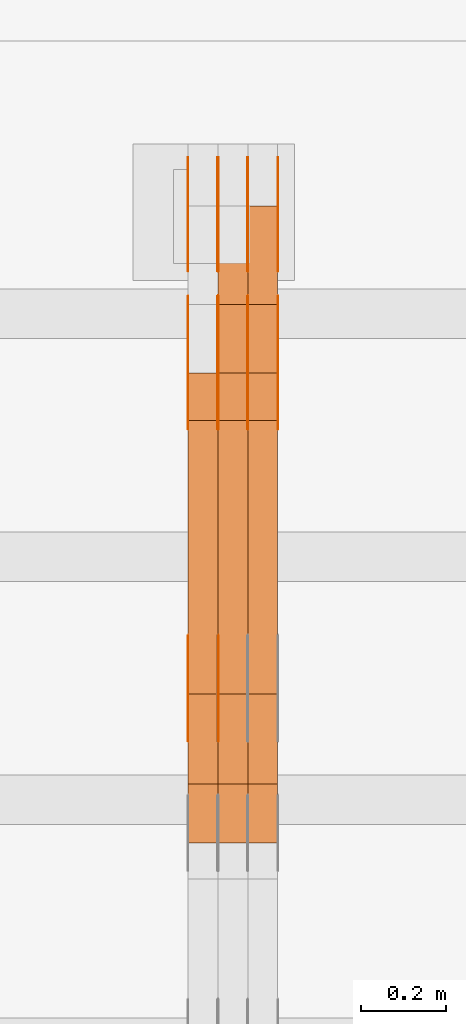
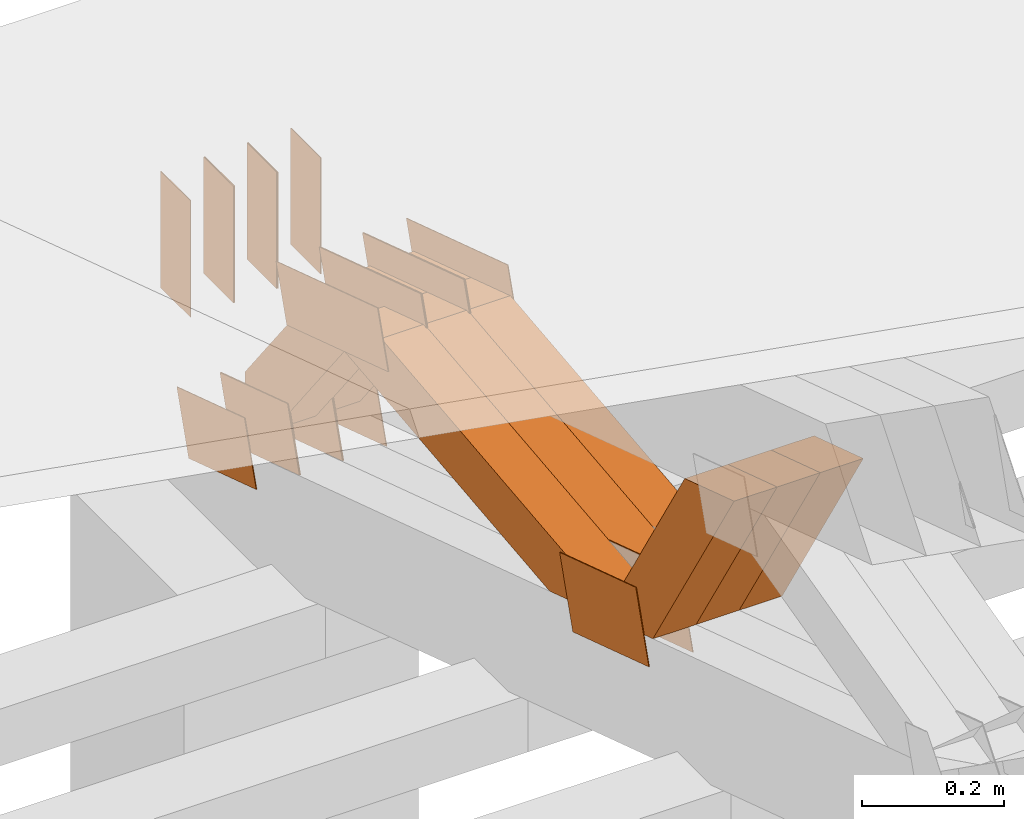
# One storey, part 360 of 385: 28 proxies.
"""IFC2X3 building model written with IfcOpenShell, lengths in millimetres."""

from ifc_helpers import new_model, entity, si_unit, converted_unit, derived_unit, direction, frame, frame_2d, origin, place, context, subcontext, project, spatial, polyline, rectangle, outline, extrude, source, transform, mapped, material, type_object, type_shapes, element, save


model = new_model("IFC2X3")

# Units and contexts
model_context = context("Model", 3, precision=0.01, world=origin(), true_north=direction((6.12303176911189e-17, 1.0)))
body_context = subcontext(model_context, "Body", "Model", "MODEL_VIEW")
ifc_project = project(units=[si_unit("LENGTHUNIT", "METRE", prefix="MILLI"), si_unit("AREAUNIT", "SQUARE_METRE"), si_unit("VOLUMEUNIT", "CUBIC_METRE"), converted_unit("PLANEANGLEUNIT", "DEGREE", entity("IfcRatioMeasure", 0.0174532925199433), si_unit("PLANEANGLEUNIT", "RADIAN"), dimensions=[0, 0, 0, 0, 0, 0, 0]), si_unit("MASSUNIT", "GRAM", prefix="KILO"), derived_unit("MASSDENSITYUNIT", [(si_unit("MASSUNIT", "GRAM", prefix="KILO"), 1), (si_unit("LENGTHUNIT", "METRE"), -3)]), si_unit("TIMEUNIT", "SECOND"), si_unit("FREQUENCYUNIT", "HERTZ"), si_unit("THERMODYNAMICTEMPERATUREUNIT", "DEGREE_CELSIUS"), derived_unit("THERMALTRANSMITTANCEUNIT", [(si_unit("MASSUNIT", "GRAM", prefix="KILO"), 1), (si_unit("THERMODYNAMICTEMPERATUREUNIT", "KELVIN"), -1), (si_unit("TIMEUNIT", "SECOND"), -3)]), derived_unit("VOLUMETRICFLOWRATEUNIT", [(si_unit("LENGTHUNIT", "METRE"), 3), (si_unit("TIMEUNIT", "SECOND"), -1)]), si_unit("ELECTRICCURRENTUNIT", "AMPERE"), si_unit("ELECTRICVOLTAGEUNIT", "VOLT"), si_unit("POWERUNIT", "WATT"), si_unit("FORCEUNIT", "NEWTON", prefix="KILO"), si_unit("ILLUMINANCEUNIT", "LUX"), si_unit("LUMINOUSFLUXUNIT", "LUMEN"), si_unit("LUMINOUSINTENSITYUNIT", "CANDELA"), derived_unit("USERDEFINED", [(si_unit("MASSUNIT", "GRAM", prefix="KILO"), -1), (si_unit("LENGTHUNIT", "METRE"), -2), (si_unit("TIMEUNIT", "SECOND"), 3), (si_unit("LUMINOUSFLUXUNIT", "LUMEN"), 1)]), derived_unit("LINEARVELOCITYUNIT", [(si_unit("LENGTHUNIT", "METRE"), 1), (si_unit("TIMEUNIT", "SECOND"), -1)]), si_unit("PRESSUREUNIT", "PASCAL"), derived_unit("USERDEFINED", [(si_unit("LENGTHUNIT", "METRE"), -2), (si_unit("MASSUNIT", "GRAM", prefix="KILO"), 1), (si_unit("TIMEUNIT", "SECOND"), -2)])], contexts=[model_context])

# Site, building, storey
site_placement = place(None, origin())
site = spatial("IfcSite", under=ifc_project, at=site_placement, CompositionType="ELEMENT")
building_placement = place(site_placement, origin())
building = spatial("IfcBuilding", under=site, at=building_placement, CompositionType="ELEMENT")
storey_placement = place(building_placement, origin())
storey = spatial("IfcBuildingStorey", under=building, at=storey_placement, Name="Default", CompositionType="ELEMENT", Elevation=0.0)

# Proxies
ifc_material_1 = material(Name="IfcSurfaceStyle #515950")
building_element_proxy_type_1 = type_object("IfcBuildingElementProxyType", PredefinedType="NOTDEFINED", material=ifc_material_1)
shared_shape_1 = source(origin(), body_context, "Body", "SweptSolid", [
    extrude(outline(polyline([(-100.000024997547, -54.0000105875654), (100.000088940899, -54.0000105875654), (99.9999100805868, 54.0000105875654), (-99.9999740239394, 54.0000105875654), (-100.000024997547, -54.0000105875654)])), frame((100.000088940899, 54.0000474633838, 0.0), z_axis=(0.0, 0.0, 1.0), x_axis=(-1.0, 0.0, 0.0)), (0.0, 0.0, 1.0), 1.3),
])
type_shapes(building_element_proxy_type_1, [shared_shape_1])
proxy_1_placement = place(building_placement, frame((42386.3, 26390.6212638563, 73.3227520411355), z_axis=(-1.0, 0.0, 0.0), x_axis=(0.0, -0.951056516295124, 0.309016994375039)))
element("IfcBuildingElementProxy", 1, at=proxy_1_placement, inside=storey, type_object=building_element_proxy_type_1, material=ifc_material_1, context=body_context, shape_type="MappedRepresentation", body=[
    mapped(shared_shape_1, transform((0.0, 0.0, 0.0), scale=1.0)),
])
ifc_material_2 = material(Name="IfcSurfaceStyle #515893")
building_element_proxy_type_2 = type_object("IfcBuildingElementProxyType", PredefinedType="NOTDEFINED", material=ifc_material_2)
shared_shape_2 = source(origin(), body_context, "Body", "SweptSolid", [
    extrude(outline(polyline([(-100.000024997547, -54.0000105875654), (100.000088940899, -54.0000105875654), (99.9999100805868, 54.0000105875654), (-99.9999740239394, 54.0000105875654), (-100.000024997547, -54.0000105875654)])), frame((100.000088940899, 54.0000474633838, 0.0), z_axis=(0.0, 0.0, 1.0), x_axis=(-1.0, 0.0, 0.0)), (0.0, 0.0, 1.0), 1.3),
])
type_shapes(building_element_proxy_type_2, [shared_shape_2])
proxy_2_placement = place(building_placement, frame((42315.0, 26390.6212638563, 73.3227520411355), z_axis=(-1.0, 0.0, 0.0), x_axis=(0.0, -0.951056516295124, 0.309016994375039)))
element("IfcBuildingElementProxy", 2, at=proxy_2_placement, inside=storey, type_object=building_element_proxy_type_2, material=ifc_material_2, context=body_context, shape_type="MappedRepresentation", body=[
    mapped(shared_shape_2, transform((0.0, 0.0, 0.0), scale=1.0)),
])
ifc_material_3 = material(Name="IfcSurfaceStyle #515836")
building_element_proxy_type_3 = type_object("IfcBuildingElementProxyType", PredefinedType="NOTDEFINED", material=ifc_material_3)
shared_shape_3 = source(origin(), body_context, "Body", "SweptSolid", [
    extrude(outline(polyline([(-100.000024997547, -54.0000105875654), (100.000088940899, -54.0000105875654), (99.9999100805868, 54.0000105875654), (-99.9999740239394, 54.0000105875654), (-100.000024997547, -54.0000105875654)])), frame((100.000088940899, 54.0000474633838, 0.0), z_axis=(0.0, 0.0, 1.0), x_axis=(-1.0, 0.0, 0.0)), (0.0, 0.0, 1.0), 1.3),
])
type_shapes(building_element_proxy_type_3, [shared_shape_3])
proxy_3_placement = place(building_placement, frame((42316.3, 26390.6212638563, 73.3227520411355), z_axis=(-1.0, 0.0, 0.0), x_axis=(0.0, -0.951056516295124, 0.309016994375039)))
element("IfcBuildingElementProxy", 3, at=proxy_3_placement, inside=storey, type_object=building_element_proxy_type_3, material=ifc_material_3, context=body_context, shape_type="MappedRepresentation", body=[
    mapped(shared_shape_3, transform((0.0, 0.0, 0.0), scale=1.0)),
])
ifc_material_4 = material(Name="IfcSurfaceStyle #515779")
building_element_proxy_type_4 = type_object("IfcBuildingElementProxyType", PredefinedType="NOTDEFINED", material=ifc_material_4)
shared_shape_4 = source(origin(), body_context, "Body", "SweptSolid", [
    extrude(outline(polyline([(-100.000024997547, -54.0000105875654), (100.000088940899, -54.0000105875654), (99.9999100805868, 54.0000105875654), (-99.9999740239394, 54.0000105875654), (-100.000024997547, -54.0000105875654)])), frame((100.000088940899, 54.0000474633838, 0.0), z_axis=(0.0, 0.0, 1.0), x_axis=(-1.0, 0.0, 0.0)), (0.0, 0.0, 1.0), 1.29999999999998),
])
type_shapes(building_element_proxy_type_4, [shared_shape_4])
proxy_4_placement = place(building_placement, frame((42245.0, 26390.6212638563, 73.3227520411355), z_axis=(-1.0, 0.0, 0.0), x_axis=(0.0, -0.951056516295124, 0.309016994375039)))
element("IfcBuildingElementProxy", 4, at=proxy_4_placement, inside=storey, type_object=building_element_proxy_type_4, material=ifc_material_4, context=body_context, shape_type="MappedRepresentation", body=[
    mapped(shared_shape_4, transform((0.0, 0.0, 0.0), scale=1.0)),
])
ifc_material_5 = material(Name="IfcSurfaceStyle #515722")
building_element_proxy_type_5 = type_object("IfcBuildingElementProxyType", PredefinedType="NOTDEFINED", material=ifc_material_5)
shared_shape_5 = source(origin(), body_context, "Body", "SweptSolid", [
    extrude(outline(polyline([(-100.000024997547, -54.0000105875654), (100.000088940899, -54.0000105875654), (99.9999100805868, 54.0000105875654), (-99.9999740239394, 54.0000105875654), (-100.000024997547, -54.0000105875654)])), frame((100.000088940899, 54.0000474633838, 0.0), z_axis=(0.0, 0.0, 1.0), x_axis=(-1.0, 0.0, 0.0)), (0.0, 0.0, 1.0), 1.29999999999998),
])
type_shapes(building_element_proxy_type_5, [shared_shape_5])
proxy_5_placement = place(building_placement, frame((42246.3, 26390.6212638563, 73.3227520411355), z_axis=(-1.0, 0.0, 0.0), x_axis=(0.0, -0.951056516295124, 0.309016994375039)))
element("IfcBuildingElementProxy", 5, at=proxy_5_placement, inside=storey, type_object=building_element_proxy_type_5, material=ifc_material_5, context=body_context, shape_type="MappedRepresentation", body=[
    mapped(shared_shape_5, transform((0.0, 0.0, 0.0), scale=1.0)),
])
ifc_material_6 = material(Name="IfcSurfaceStyle #515665")
building_element_proxy_type_6 = type_object("IfcBuildingElementProxyType", PredefinedType="NOTDEFINED", material=ifc_material_6)
shared_shape_6 = source(origin(), body_context, "Body", "SweptSolid", [
    extrude(outline(polyline([(-100.000024997547, -54.0000105875654), (100.000088940899, -54.0000105875654), (99.9999100805868, 54.0000105875654), (-99.9999740239394, 54.0000105875654), (-100.000024997547, -54.0000105875654)])), frame((100.000088940899, 54.0000474633838, 0.0), z_axis=(0.0, 0.0, 1.0), x_axis=(-1.0, 0.0, 0.0)), (0.0, 0.0, 1.0), 1.29999999999999),
])
type_shapes(building_element_proxy_type_6, [shared_shape_6])
proxy_6_placement = place(building_placement, frame((42175.0, 26390.6212638563, 73.3227520411355), z_axis=(-1.0, 0.0, 0.0), x_axis=(0.0, -0.951056516295124, 0.309016994375039)))
element("IfcBuildingElementProxy", 6, at=proxy_6_placement, inside=storey, type_object=building_element_proxy_type_6, material=ifc_material_6, context=body_context, shape_type="MappedRepresentation", body=[
    mapped(shared_shape_6, transform((0.0, 0.0, 0.0), scale=1.0)),
])
ifc_material_7 = material(Name="IfcSurfaceStyle #503752")
building_element_proxy_type_7 = type_object("IfcBuildingElementProxyType", PredefinedType="NOTDEFINED", material=ifc_material_7)
shared_shape_7 = source(origin(), body_context, "Body", "SweptSolid", [
    extrude(outline(polyline([(-112.50003853564, -60.0000121429077), (112.50002982902, -60.0000121429077), (112.500043250865, 60.0000121429077), (-112.500034544245, 60.0000121429077), (-112.50003853564, -60.0000121429077)])), frame((112.500056021398, 60.0000121429077, 0.0), z_axis=(0.0, 0.0, 1.0), x_axis=(-1.0, 0.0, 0.0)), (0.0, 0.0, 1.0), 1.29999999999998),
])
type_shapes(building_element_proxy_type_7, [shared_shape_7])
proxy_7_placement = place(building_placement, frame((42246.3, 25310.2182710495, 430.675738123044), z_axis=(-1.0, 0.0, 0.0), x_axis=(0.0, -0.951056516295124, 0.309016994375039)))
element("IfcBuildingElementProxy", 7, at=proxy_7_placement, inside=storey, type_object=building_element_proxy_type_7, material=ifc_material_7, context=body_context, shape_type="MappedRepresentation", body=[
    mapped(shared_shape_7, transform((0.0, 0.0, 0.0), scale=1.0)),
])
ifc_material_8 = material(Name="IfcSurfaceStyle #503695")
building_element_proxy_type_8 = type_object("IfcBuildingElementProxyType", PredefinedType="NOTDEFINED", material=ifc_material_8)
shared_shape_8 = source(origin(), body_context, "Body", "SweptSolid", [
    extrude(outline(polyline([(-112.50003853564, -60.0000121429077), (112.50002982902, -60.0000121429077), (112.500043250865, 60.0000121429077), (-112.500034544245, 60.0000121429077), (-112.50003853564, -60.0000121429077)])), frame((112.500056021398, 60.0000121429077, 0.0), z_axis=(0.0, 0.0, 1.0), x_axis=(-1.0, 0.0, 0.0)), (0.0, 0.0, 1.0), 1.29999999999999),
])
type_shapes(building_element_proxy_type_8, [shared_shape_8])
proxy_8_placement = place(building_placement, frame((42175.0, 25310.2182710495, 430.675738123044), z_axis=(-1.0, 0.0, 0.0), x_axis=(0.0, -0.951056516295124, 0.309016994375039)))
element("IfcBuildingElementProxy", 8, at=proxy_8_placement, inside=storey, type_object=building_element_proxy_type_8, material=ifc_material_8, context=body_context, shape_type="MappedRepresentation", body=[
    mapped(shared_shape_8, transform((0.0, 0.0, 0.0), scale=1.0)),
])
ifc_material_9 = material(Name="IfcSurfaceStyle #503296")
building_element_proxy_type_9 = type_object("IfcBuildingElementProxyType", PredefinedType="NOTDEFINED", material=ifc_material_9)
shared_shape_9 = source(origin(), body_context, "Body", "SweptSolid", [
    extrude(outline(polyline([(-149.999901061401, -48.0000057587028), (150.000035297123, -48.0000057587028), (149.999910491851, 48.0000057587028), (-150.000044727574, 48.0000057587028), (-149.999901061401, -48.0000057587028)])), frame((150.000035297123, 48.0000632585775, 0.0), z_axis=(0.0, 0.0, 1.0), x_axis=(-1.0, 0.0, 0.0)), (0.0, 0.0, 1.0), 1.29999999999999),
])
type_shapes(building_element_proxy_type_9, [shared_shape_9])
proxy_9_placement = place(building_placement, frame((42386.3, 26115.0176968219, 469.58296924555), z_axis=(-1.0, 0.0, 0.0), x_axis=(0.0, -0.951056516295154, 0.309016994374948)))
element("IfcBuildingElementProxy", 9, at=proxy_9_placement, inside=storey, type_object=building_element_proxy_type_9, material=ifc_material_9, context=body_context, shape_type="MappedRepresentation", body=[
    mapped(shared_shape_9, transform((0.0, 0.0, 0.0), scale=1.0)),
])
ifc_material_10 = material(Name="IfcSurfaceStyle #503239")
building_element_proxy_type_10 = type_object("IfcBuildingElementProxyType", PredefinedType="NOTDEFINED", material=ifc_material_10)
shared_shape_10 = source(origin(), body_context, "Body", "SweptSolid", [
    extrude(outline(polyline([(-149.999901061401, -48.0000057587028), (150.000035297123, -48.0000057587028), (149.999910491851, 48.0000057587028), (-150.000044727574, 48.0000057587028), (-149.999901061401, -48.0000057587028)])), frame((150.000035297123, 48.0000632585775, 0.0), z_axis=(0.0, 0.0, 1.0), x_axis=(-1.0, 0.0, 0.0)), (0.0, 0.0, 1.0), 1.29999999999999),
])
type_shapes(building_element_proxy_type_10, [shared_shape_10])
proxy_10_placement = place(building_placement, frame((42315.0, 26115.0176968219, 469.58296924555), z_axis=(-1.0, 0.0, 0.0), x_axis=(0.0, -0.951056516295154, 0.309016994374948)))
element("IfcBuildingElementProxy", 10, at=proxy_10_placement, inside=storey, type_object=building_element_proxy_type_10, material=ifc_material_10, context=body_context, shape_type="MappedRepresentation", body=[
    mapped(shared_shape_10, transform((0.0, 0.0, 0.0), scale=1.0)),
])
ifc_material_11 = material(Name="IfcSurfaceStyle #503182")
building_element_proxy_type_11 = type_object("IfcBuildingElementProxyType", PredefinedType="NOTDEFINED", material=ifc_material_11)
shared_shape_11 = source(origin(), body_context, "Body", "SweptSolid", [
    extrude(outline(polyline([(-149.999901061401, -48.0000057587028), (150.000035297123, -48.0000057587028), (149.999910491851, 48.0000057587028), (-150.000044727574, 48.0000057587028), (-149.999901061401, -48.0000057587028)])), frame((150.000035297123, 48.0000632585775, 0.0), z_axis=(0.0, 0.0, 1.0), x_axis=(-1.0, 0.0, 0.0)), (0.0, 0.0, 1.0), 1.29999999999999),
])
type_shapes(building_element_proxy_type_11, [shared_shape_11])
proxy_11_placement = place(building_placement, frame((42316.3, 26115.0176968219, 469.58296924555), z_axis=(-1.0, 0.0, 0.0), x_axis=(0.0, -0.951056516295154, 0.309016994374948)))
element("IfcBuildingElementProxy", 11, at=proxy_11_placement, inside=storey, type_object=building_element_proxy_type_11, material=ifc_material_11, context=body_context, shape_type="MappedRepresentation", body=[
    mapped(shared_shape_11, transform((0.0, 0.0, 0.0), scale=1.0)),
])
ifc_material_12 = material(Name="IfcSurfaceStyle #503125")
building_element_proxy_type_12 = type_object("IfcBuildingElementProxyType", PredefinedType="NOTDEFINED", material=ifc_material_12)
shared_shape_12 = source(origin(), body_context, "Body", "SweptSolid", [
    extrude(outline(polyline([(-149.999901061401, -48.0000057587028), (150.000035297123, -48.0000057587028), (149.999910491851, 48.0000057587028), (-150.000044727574, 48.0000057587028), (-149.999901061401, -48.0000057587028)])), frame((150.000035297123, 48.0000632585775, 0.0), z_axis=(0.0, 0.0, 1.0), x_axis=(-1.0, 0.0, 0.0)), (0.0, 0.0, 1.0), 1.29999999999998),
])
type_shapes(building_element_proxy_type_12, [shared_shape_12])
proxy_12_placement = place(building_placement, frame((42245.0, 26115.0176968219, 469.58296924555), z_axis=(-1.0, 0.0, 0.0), x_axis=(0.0, -0.951056516295154, 0.309016994374948)))
element("IfcBuildingElementProxy", 12, at=proxy_12_placement, inside=storey, type_object=building_element_proxy_type_12, material=ifc_material_12, context=body_context, shape_type="MappedRepresentation", body=[
    mapped(shared_shape_12, transform((0.0, 0.0, 0.0), scale=1.0)),
])
ifc_material_13 = material(Name="IfcSurfaceStyle #503068")
building_element_proxy_type_13 = type_object("IfcBuildingElementProxyType", PredefinedType="NOTDEFINED", material=ifc_material_13)
shared_shape_13 = source(origin(), body_context, "Body", "SweptSolid", [
    extrude(outline(polyline([(-149.999901061401, -48.0000057587028), (150.000035297123, -48.0000057587028), (149.999910491851, 48.0000057587028), (-150.000044727574, 48.0000057587028), (-149.999901061401, -48.0000057587028)])), frame((150.000035297123, 48.0000632585775, 0.0), z_axis=(0.0, 0.0, 1.0), x_axis=(-1.0, 0.0, 0.0)), (0.0, 0.0, 1.0), 1.29999999999998),
])
type_shapes(building_element_proxy_type_13, [shared_shape_13])
proxy_13_placement = place(building_placement, frame((42246.3, 26115.0176968219, 469.58296924555), z_axis=(-1.0, 0.0, 0.0), x_axis=(0.0, -0.951056516295154, 0.309016994374948)))
element("IfcBuildingElementProxy", 13, at=proxy_13_placement, inside=storey, type_object=building_element_proxy_type_13, material=ifc_material_13, context=body_context, shape_type="MappedRepresentation", body=[
    mapped(shared_shape_13, transform((0.0, 0.0, 0.0), scale=1.0)),
])
ifc_material_14 = material(Name="IfcSurfaceStyle #503011")
building_element_proxy_type_14 = type_object("IfcBuildingElementProxyType", PredefinedType="NOTDEFINED", material=ifc_material_14)
shared_shape_14 = source(origin(), body_context, "Body", "SweptSolid", [
    extrude(outline(polyline([(-149.999901061401, -48.0000057587028), (150.000035297123, -48.0000057587028), (149.999910491851, 48.0000057587028), (-150.000044727574, 48.0000057587028), (-149.999901061401, -48.0000057587028)])), frame((150.000035297123, 48.0000632585775, 0.0), z_axis=(0.0, 0.0, 1.0), x_axis=(-1.0, 0.0, 0.0)), (0.0, 0.0, 1.0), 1.29999999999998),
])
type_shapes(building_element_proxy_type_14, [shared_shape_14])
proxy_14_placement = place(building_placement, frame((42175.0, 26115.0176968219, 469.58296924555), z_axis=(-1.0, 0.0, 0.0), x_axis=(0.0, -0.951056516295154, 0.309016994374948)))
element("IfcBuildingElementProxy", 14, at=proxy_14_placement, inside=storey, type_object=building_element_proxy_type_14, material=ifc_material_14, context=body_context, shape_type="MappedRepresentation", body=[
    mapped(shared_shape_14, transform((0.0, 0.0, 0.0), scale=1.0)),
])
ifc_material_15 = material(Name="IfcSurfaceStyle #502954")
building_element_proxy_type_15 = type_object("IfcBuildingElementProxyType", PredefinedType="NOTDEFINED", material=ifc_material_15)
shared_shape_15 = source(origin(), body_context, "Body", "SweptSolid", [
    extrude(rectangle(XDim=200.0, YDim=84.0000000000005, at=frame_2d((-2.1316282072803e-14, 1.06581410364015e-14), x_axis=(1.0, 0.0))), frame((100.0, 42.0, 0.0), z_axis=(0.0, 0.0, 1.0), x_axis=(-1.0, 0.0, 0.0)), (0.0, 0.0, 1.0), 1.3),
])
type_shapes(building_element_proxy_type_15, [shared_shape_15])
proxy_15_placement = place(building_placement, frame((42386.3, 26469.5000000002, 518.521545410156), z_axis=(-1.0, 0.0, 0.0), x_axis=(0.0, 0.0, -1.0)))
element("IfcBuildingElementProxy", 15, at=proxy_15_placement, inside=storey, type_object=building_element_proxy_type_15, material=ifc_material_15, context=body_context, shape_type="MappedRepresentation", body=[
    mapped(shared_shape_15, transform((0.0, 0.0, 0.0), scale=1.0)),
])
ifc_material_16 = material(Name="IfcSurfaceStyle #502897")
building_element_proxy_type_16 = type_object("IfcBuildingElementProxyType", PredefinedType="NOTDEFINED", material=ifc_material_16)
shared_shape_16 = source(origin(), body_context, "Body", "SweptSolid", [
    extrude(rectangle(XDim=200.0, YDim=84.0000000000005, at=frame_2d((-2.1316282072803e-14, 1.06581410364015e-14), x_axis=(1.0, 0.0))), frame((100.0, 42.0, 0.0), z_axis=(0.0, 0.0, 1.0), x_axis=(-1.0, 0.0, 0.0)), (0.0, 0.0, 1.0), 1.3),
])
type_shapes(building_element_proxy_type_16, [shared_shape_16])
proxy_16_placement = place(building_placement, frame((42315.0, 26469.5000000002, 518.521545410156), z_axis=(-1.0, 0.0, 0.0), x_axis=(0.0, 0.0, -1.0)))
element("IfcBuildingElementProxy", 16, at=proxy_16_placement, inside=storey, type_object=building_element_proxy_type_16, material=ifc_material_16, context=body_context, shape_type="MappedRepresentation", body=[
    mapped(shared_shape_16, transform((0.0, 0.0, 0.0), scale=1.0)),
])
ifc_material_17 = material(Name="IfcSurfaceStyle #502840")
building_element_proxy_type_17 = type_object("IfcBuildingElementProxyType", PredefinedType="NOTDEFINED", material=ifc_material_17)
shared_shape_17 = source(origin(), body_context, "Body", "SweptSolid", [
    extrude(rectangle(XDim=200.0, YDim=84.0000000000005, at=frame_2d((-2.1316282072803e-14, 1.06581410364015e-14), x_axis=(1.0, 0.0))), frame((100.0, 42.0, 0.0), z_axis=(0.0, 0.0, 1.0), x_axis=(-1.0, 0.0, 0.0)), (0.0, 0.0, 1.0), 1.3),
])
type_shapes(building_element_proxy_type_17, [shared_shape_17])
proxy_17_placement = place(building_placement, frame((42316.3, 26469.5000000002, 518.521545410156), z_axis=(-1.0, 0.0, 0.0), x_axis=(0.0, 0.0, -1.0)))
element("IfcBuildingElementProxy", 17, at=proxy_17_placement, inside=storey, type_object=building_element_proxy_type_17, material=ifc_material_17, context=body_context, shape_type="MappedRepresentation", body=[
    mapped(shared_shape_17, transform((0.0, 0.0, 0.0), scale=1.0)),
])
ifc_material_18 = material(Name="IfcSurfaceStyle #502783")
building_element_proxy_type_18 = type_object("IfcBuildingElementProxyType", PredefinedType="NOTDEFINED", material=ifc_material_18)
shared_shape_18 = source(origin(), body_context, "Body", "SweptSolid", [
    extrude(rectangle(XDim=200.0, YDim=84.0000000000005, at=frame_2d((-2.1316282072803e-14, 1.06581410364015e-14), x_axis=(1.0, 0.0))), frame((100.0, 42.0, 0.0), z_axis=(0.0, 0.0, 1.0), x_axis=(-1.0, 0.0, 0.0)), (0.0, 0.0, 1.0), 1.29999999999998),
])
type_shapes(building_element_proxy_type_18, [shared_shape_18])
proxy_18_placement = place(building_placement, frame((42245.0, 26469.5000000002, 518.521545410156), z_axis=(-1.0, 0.0, 0.0), x_axis=(0.0, 0.0, -1.0)))
element("IfcBuildingElementProxy", 18, at=proxy_18_placement, inside=storey, type_object=building_element_proxy_type_18, material=ifc_material_18, context=body_context, shape_type="MappedRepresentation", body=[
    mapped(shared_shape_18, transform((0.0, 0.0, 0.0), scale=1.0)),
])
ifc_material_19 = material(Name="IfcSurfaceStyle #502726")
building_element_proxy_type_19 = type_object("IfcBuildingElementProxyType", PredefinedType="NOTDEFINED", material=ifc_material_19)
shared_shape_19 = source(origin(), body_context, "Body", "SweptSolid", [
    extrude(rectangle(XDim=200.0, YDim=84.0000000000005, at=frame_2d((-2.1316282072803e-14, 1.06581410364015e-14), x_axis=(1.0, 0.0))), frame((100.0, 42.0, 0.0), z_axis=(0.0, 0.0, 1.0), x_axis=(-1.0, 0.0, 0.0)), (0.0, 0.0, 1.0), 1.29999999999998),
])
type_shapes(building_element_proxy_type_19, [shared_shape_19])
proxy_19_placement = place(building_placement, frame((42246.3, 26469.5000000002, 518.521545410156), z_axis=(-1.0, 0.0, 0.0), x_axis=(0.0, 0.0, -1.0)))
element("IfcBuildingElementProxy", 19, at=proxy_19_placement, inside=storey, type_object=building_element_proxy_type_19, material=ifc_material_19, context=body_context, shape_type="MappedRepresentation", body=[
    mapped(shared_shape_19, transform((0.0, 0.0, 0.0), scale=1.0)),
])
ifc_material_20 = material(Name="IfcSurfaceStyle #502669")
building_element_proxy_type_20 = type_object("IfcBuildingElementProxyType", PredefinedType="NOTDEFINED", material=ifc_material_20)
shared_shape_20 = source(origin(), body_context, "Body", "SweptSolid", [
    extrude(rectangle(XDim=200.0, YDim=84.0000000000005, at=frame_2d((-2.1316282072803e-14, 1.06581410364015e-14), x_axis=(1.0, 0.0))), frame((100.0, 42.0, 0.0), z_axis=(0.0, 0.0, 1.0), x_axis=(-1.0, 0.0, 0.0)), (0.0, 0.0, 1.0), 1.29999999999999),
])
type_shapes(building_element_proxy_type_20, [shared_shape_20])
proxy_20_placement = place(building_placement, frame((42175.0, 26469.5000000002, 518.521545410156), z_axis=(-1.0, 0.0, 0.0), x_axis=(0.0, 0.0, -1.0)))
element("IfcBuildingElementProxy", 20, at=proxy_20_placement, inside=storey, type_object=building_element_proxy_type_20, material=ifc_material_20, context=body_context, shape_type="MappedRepresentation", body=[
    mapped(shared_shape_20, transform((0.0, 0.0, 0.0), scale=1.0)),
])
ifc_material_21 = material(Name="IfcSurfaceStyle #491938")
building_element_proxy_type_21 = type_object("IfcBuildingElementProxyType", Name="T1-W31 491936", PredefinedType="NOTDEFINED", material=ifc_material_21)
shared_shape_21 = source(origin(), body_context, "Body", "SweptSolid", [
    extrude(outline(polyline([(-201.245318299844, -47.5000121670808), (204.413774229459, -47.5000121670808), (182.034306640891, 5.35692244583164e-05), (126.70380769348, 47.4999853824686), (-311.906570263987, 47.4999853824686), (-201.245318299844, -47.5000121670808)])), frame((204.413774229459, 47.5002684334588, 0.0), z_axis=(0.0, 0.0, 1.0), x_axis=(-1.0, 0.0, 0.0)), (0.0, 0.0, 1.0), 70.0),
])
type_shapes(building_element_proxy_type_21, [shared_shape_21])
proxy_21_placement = place(building_placement, frame((42385.0, 25127.5652647985, 487.27008059185), z_axis=(-1.0, 0.0, 0.0), x_axis=(0.0, -0.520333970303023, 0.853962855953755)))
element("IfcBuildingElementProxy", 21, at=proxy_21_placement, inside=storey, type_object=building_element_proxy_type_21, material=ifc_material_21, Name="T1-W31", context=body_context, shape_type="MappedRepresentation", body=[
    mapped(shared_shape_21, transform((0.0, 0.0, 0.0), scale=1.0)),
])
ifc_material_22 = material(Name="IfcSurfaceStyle #491872")
building_element_proxy_type_22 = type_object("IfcBuildingElementProxyType", Name="T1-W31 491870", PredefinedType="NOTDEFINED", material=ifc_material_22)
shared_shape_22 = source(origin(), body_context, "Body", "SweptSolid", [
    extrude(outline(polyline([(-201.245318299844, -47.5000121670808), (204.413774229459, -47.5000121670808), (182.034306640891, 5.35692244583164e-05), (126.70380769348, 47.4999853824686), (-311.906570263987, 47.4999853824686), (-201.245318299844, -47.5000121670808)])), frame((204.413774229459, 47.5002684334588, 0.0), z_axis=(0.0, 0.0, 1.0), x_axis=(-1.0, 0.0, 0.0)), (0.0, 0.0, 1.0), 70.0),
])
type_shapes(building_element_proxy_type_22, [shared_shape_22])
proxy_22_placement = place(building_placement, frame((42315.0, 25127.5652647985, 487.27008059185), z_axis=(-1.0, 0.0, 0.0), x_axis=(0.0, -0.520333970303023, 0.853962855953755)))
element("IfcBuildingElementProxy", 22, at=proxy_22_placement, inside=storey, type_object=building_element_proxy_type_22, material=ifc_material_22, Name="T1-W31", context=body_context, shape_type="MappedRepresentation", body=[
    mapped(shared_shape_22, transform((0.0, 0.0, 0.0), scale=1.0)),
])
ifc_material_23 = material(Name="IfcSurfaceStyle #491806")
building_element_proxy_type_23 = type_object("IfcBuildingElementProxyType", Name="T1-W31 491804", PredefinedType="NOTDEFINED", material=ifc_material_23)
shared_shape_23 = source(origin(), body_context, "Body", "SweptSolid", [
    extrude(outline(polyline([(-201.245318299844, -47.5000121670808), (204.413774229459, -47.5000121670808), (182.034306640891, 5.35692244583164e-05), (126.70380769348, 47.4999853824686), (-311.906570263987, 47.4999853824686), (-201.245318299844, -47.5000121670808)])), frame((204.413774229459, 47.5002684334588, 0.0), z_axis=(0.0, 0.0, 1.0), x_axis=(-1.0, 0.0, 0.0)), (0.0, 0.0, 1.0), 70.0),
])
type_shapes(building_element_proxy_type_23, [shared_shape_23])
proxy_23_placement = place(building_placement, frame((42245.0, 25127.5652647985, 487.27008059185), z_axis=(-1.0, 0.0, 0.0), x_axis=(0.0, -0.520333970303023, 0.853962855953755)))
element("IfcBuildingElementProxy", 23, at=proxy_23_placement, inside=storey, type_object=building_element_proxy_type_23, material=ifc_material_23, Name="T1-W31", context=body_context, shape_type="MappedRepresentation", body=[
    mapped(shared_shape_23, transform((0.0, 0.0, 0.0), scale=1.0)),
])
ifc_material_24 = material(Name="IfcSurfaceStyle #491542")
building_element_proxy_type_24 = type_object("IfcBuildingElementProxyType", Name="T1-W4 491540", PredefinedType="NOTDEFINED", material=ifc_material_24)
shared_shape_24 = source(origin(), body_context, "Body", "SweptSolid", [
    extrude(outline(polyline([(-510.077325435179, -47.4999981284922), (188.854793418912, -47.4999981284922), (294.906688207675, 1.67015383116809e-05), (324.289382923648, 47.499989777723), (-297.973539115057, 47.4999897777231), (-510.077325435179, -47.4999981284922)])), frame((324.289382923648, 47.5000278316275, 0.0), z_axis=(0.0, 0.0, 1.0), x_axis=(-1.0, 0.0, 0.0)), (0.0, 0.0, 1.0), 70.0),
])
type_shapes(building_element_proxy_type_24, [shared_shape_24])
proxy_24_placement = place(building_placement, frame((42385.0, 25996.2241251556, 525.69905884318), z_axis=(-1.0, 0.0, 0.0), x_axis=(0.0, -0.994287125203057, -0.106738524701444)))
element("IfcBuildingElementProxy", 24, at=proxy_24_placement, inside=storey, type_object=building_element_proxy_type_24, material=ifc_material_24, Name="T1-W4", context=body_context, shape_type="MappedRepresentation", body=[
    mapped(shared_shape_24, transform((0.0, 0.0, 0.0), scale=1.0)),
])
ifc_material_25 = material(Name="IfcSurfaceStyle #491476")
building_element_proxy_type_25 = type_object("IfcBuildingElementProxyType", Name="T1-W4 491474", PredefinedType="NOTDEFINED", material=ifc_material_25)
shared_shape_25 = source(origin(), body_context, "Body", "SweptSolid", [
    extrude(outline(polyline([(-510.077325435179, -47.4999981284922), (188.854793418912, -47.4999981284922), (294.906688207675, 1.67015383116809e-05), (324.289382923648, 47.499989777723), (-297.973539115057, 47.4999897777231), (-510.077325435179, -47.4999981284922)])), frame((324.289382923648, 47.5000278316275, 0.0), z_axis=(0.0, 0.0, 1.0), x_axis=(-1.0, 0.0, 0.0)), (0.0, 0.0, 1.0), 70.0),
])
type_shapes(building_element_proxy_type_25, [shared_shape_25])
proxy_25_placement = place(building_placement, frame((42315.0, 25996.2241251556, 525.69905884318), z_axis=(-1.0, 0.0, 0.0), x_axis=(0.0, -0.994287125203057, -0.106738524701444)))
element("IfcBuildingElementProxy", 25, at=proxy_25_placement, inside=storey, type_object=building_element_proxy_type_25, material=ifc_material_25, Name="T1-W4", context=body_context, shape_type="MappedRepresentation", body=[
    mapped(shared_shape_25, transform((0.0, 0.0, 0.0), scale=1.0)),
])
ifc_material_26 = material(Name="IfcSurfaceStyle #491410")
building_element_proxy_type_26 = type_object("IfcBuildingElementProxyType", Name="T1-W4 491408", PredefinedType="NOTDEFINED", material=ifc_material_26)
shared_shape_26 = source(origin(), body_context, "Body", "SweptSolid", [
    extrude(outline(polyline([(-510.077325435179, -47.4999981284922), (188.854793418912, -47.4999981284922), (294.906688207675, 1.67015383116809e-05), (324.289382923648, 47.499989777723), (-297.973539115057, 47.4999897777231), (-510.077325435179, -47.4999981284922)])), frame((324.289382923648, 47.5000278316275, 0.0), z_axis=(0.0, 0.0, 1.0), x_axis=(-1.0, 0.0, 0.0)), (0.0, 0.0, 1.0), 70.0),
])
type_shapes(building_element_proxy_type_26, [shared_shape_26])
proxy_26_placement = place(building_placement, frame((42245.0, 25996.2241251556, 525.69905884318), z_axis=(-1.0, 0.0, 0.0), x_axis=(0.0, -0.994287125203057, -0.106738524701444)))
element("IfcBuildingElementProxy", 26, at=proxy_26_placement, inside=storey, type_object=building_element_proxy_type_26, material=ifc_material_26, Name="T1-W4", context=body_context, shape_type="MappedRepresentation", body=[
    mapped(shared_shape_26, transform((0.0, 0.0, 0.0), scale=1.0)),
])
ifc_material_27 = material(Name="IfcSurfaceStyle #491146")
building_element_proxy_type_27 = type_object("IfcBuildingElementProxyType", Name="T1-W21 491144", PredefinedType="NOTDEFINED", material=ifc_material_27)
shared_shape_27 = source(origin(), body_context, "Body", "SweptSolid", [
    extrude(outline(polyline([(-209.199362597501, -47.5000308982766), (168.813164734153, -47.5000308982766), (229.900717355638, -2.18385470334148e-05), (159.828709317766, 47.5000418175501), (-349.343228810055, 47.5000418175502), (-209.199362597501, -47.5000308982766)])), frame((229.900720156071, 47.5000418175501, 0.0), z_axis=(0.0, 0.0, 1.0), x_axis=(-1.0, 0.0, 0.0)), (0.0, 0.0, 1.0), 70.0),
])
type_shapes(building_element_proxy_type_27, [shared_shape_27])
proxy_27_placement = place(building_placement, frame((42385.0, 26317.5019908272, 112.518372832984), z_axis=(-1.0, 0.0, 0.0), x_axis=(0.0, -0.613839629272042, 0.789430750310097)))
element("IfcBuildingElementProxy", 27, at=proxy_27_placement, inside=storey, type_object=building_element_proxy_type_27, material=ifc_material_27, Name="T1-W21", context=body_context, shape_type="MappedRepresentation", body=[
    mapped(shared_shape_27, transform((0.0, 0.0, 0.0), scale=1.0)),
])
ifc_material_28 = material(Name="IfcSurfaceStyle #491080")
building_element_proxy_type_28 = type_object("IfcBuildingElementProxyType", Name="T1-W21 491078", PredefinedType="NOTDEFINED", material=ifc_material_28)
shared_shape_28 = source(origin(), body_context, "Body", "SweptSolid", [
    extrude(outline(polyline([(-209.199362597501, -47.5000308982766), (168.813164734153, -47.5000308982766), (229.900717355638, -2.18385470334148e-05), (159.828709317766, 47.5000418175501), (-349.343228810055, 47.5000418175502), (-209.199362597501, -47.5000308982766)])), frame((229.900720156071, 47.5000418175501, 0.0), z_axis=(0.0, 0.0, 1.0), x_axis=(-1.0, 0.0, 0.0)), (0.0, 0.0, 1.0), 70.0),
])
type_shapes(building_element_proxy_type_28, [shared_shape_28])
proxy_28_placement = place(building_placement, frame((42315.0, 26317.5019908272, 112.518372832984), z_axis=(-1.0, 0.0, 0.0), x_axis=(0.0, -0.613839629272042, 0.789430750310097)))
element("IfcBuildingElementProxy", 28, at=proxy_28_placement, inside=storey, type_object=building_element_proxy_type_28, material=ifc_material_28, Name="T1-W21", context=body_context, shape_type="MappedRepresentation", body=[
    mapped(shared_shape_28, transform((0.0, 0.0, 0.0), scale=1.0)),
])

save(model, "model.ifc")
